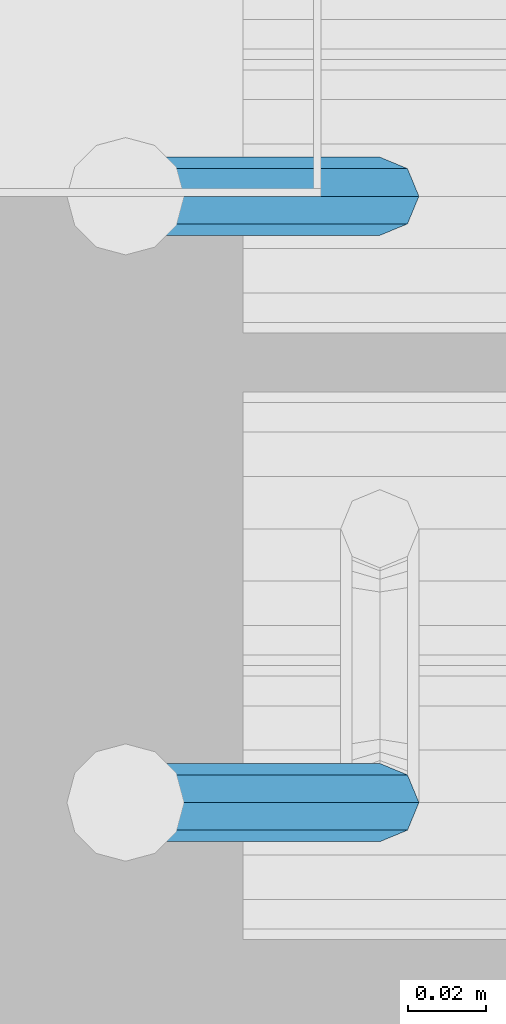
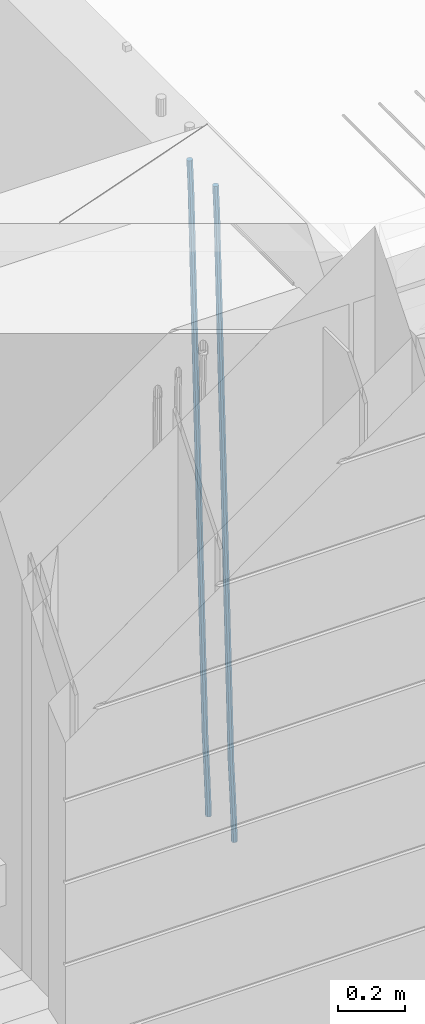
# One storey, part 99 of 350: 2 beams, 1 element without a shape of its own.
"""IFC2X3 building model written with IfcOpenShell, lengths in millimetres."""

from ifc_helpers import new_model, si_unit, frame, origin_with_axes, place, context, subcontext, project, spatial, faceted_brep, material, type_object, element, aggregate, save


model = new_model("IFC2X3")

# Units and contexts
model_context = context("Model", 3, precision=1e-05, world=origin_with_axes())
body_context = subcontext(model_context, "Body", "Model", "MODEL_VIEW")
ifc_project = project(units=[si_unit("LENGTHUNIT", "METRE", prefix="MILLI"), si_unit("AREAUNIT", "SQUARE_METRE"), si_unit("VOLUMEUNIT", "CUBIC_METRE"), si_unit("MASSUNIT", "GRAM", prefix="KILO"), si_unit("TIMEUNIT", "SECOND"), si_unit("PLANEANGLEUNIT", "RADIAN"), si_unit("SOLIDANGLEUNIT", "STERADIAN"), si_unit("THERMODYNAMICTEMPERATUREUNIT", "DEGREE_CELSIUS"), si_unit("LUMINOUSINTENSITYUNIT", "LUMEN")], contexts=[model_context])

# Site, building, storey
site_placement = place(None, origin_with_axes())
site = spatial("IfcSite", under=ifc_project, at=site_placement, CompositionType="ELEMENT")
building_placement = place(site_placement, origin_with_axes())
building = spatial("IfcBuilding", under=site, at=building_placement, CompositionType="ELEMENT")
storey_placement = place(building_placement, origin_with_axes())
storey = spatial("IfcBuildingStorey", under=building, at=storey_placement, Name="2", CompositionType="ELEMENT", Elevation=0.0)

# Assembly, beams
assembly_placement = place(storey_placement, origin_with_axes())
assembly = element("IfcElementAssembly", 1, at=assembly_placement, inside=storey, AssemblyPlace="NOTDEFINED", PredefinedType="REINFORCEMENT_UNIT")
ifc_material = material()
beam_type = type_object("IfcBeamType", Name="D20", PredefinedType="NOTDEFINED")
beam_1_placement = place(assembly_placement, frame((16725.0000022791, 8665.00000000393, 84990.0), z_axis=(-0.999642804636942, -0.000205726999925762, -0.0267249099902983), x_axis=(-0.0267249099948371, 4.30000201934385e-08, 0.999642825806181)))
beam_1 = element("IfcBeam", 2, at=beam_1_placement, type_object=beam_type, material=ifc_material, Name="JM20", ObjectType="D20", context=body_context, shape_type="Brep", body=[
    faceted_brep([(0.0, -10.0, 0.0), (-4.19531716033816e-08, -7.07106781186667, -7.07106781187031), (60.4266690400545, -7.0710677960451, -7.07106780570757), (60.4266690441291, -9.99999998418934, 6.15546014159918e-09), (0.0, 0.0, -10.0), (60.426669036824, 1.58106558956206e-08, -9.99999999384454), (4.196772351861e-08, 7.07106781186303, -7.07106781186667), (60.4266690363438, 7.07106782768096, -7.07106780570757), (0.0, 10.0, 0.0), (60.4266690388904, 10.0000000158179, 6.15182216279209e-09), (4.196772351861e-08, 7.07106781185939, 7.07106781185939), (60.4266690429649, 7.07106782768096, 7.07106781802577), (0.0, 0.0, 10.0), (60.4266690461809, 1.58179318532348e-08, 10.0000000061555), (-4.19531716033816e-08, -7.07106781187031, 7.07106781185939), (60.4266690466611, -7.07106779605238, 7.07106781802213), (61.0378400410118, -7.07106779588503, -7.07106780564936), (60.991799419251, -9.99999998403655, 6.21366780251265e-09), (61.0569027789461, 1.5985278878361e-08, -9.99999999378269), (61.0378209396877, 7.07106782784831, -7.07106780564936), (60.9917724058905, 10.0000000159635, 6.21366780251265e-09), (60.9457317841297, 7.07106782781193, 7.0710678180767), (60.9266690461809, 1.59488990902901e-08, 10.0000000062028), (60.9457508854539, -7.07106779591413, 7.0710678180767), (61.6489592143771, -7.07106614513759, -7.06310863441468), (61.5568818710308, -9.9999984576425, 0.00735959856683621), (61.6870830769039, 1.71821739058942e-06, -9.99179257185824), (61.6489210170112, 7.07106947854481, -7.06310888312146), (61.556827851804, 10.0000015422847, 0.00735924683976918), (61.4647505084577, 7.07106922979438, 7.07782747982128), (61.4266266459163, 1.36643211590126e-06, 10.0065114172685), (61.464788705809, -7.07106639389531, 7.07782772852806), (176.543135720174, -7.07075579406956, -5.56673531796696), (176.451058376813, -9.99968810657447, 1.50373291501455), (176.581259582701, 0.000312069292704109, -8.49541925541052), (176.543097522794, 7.07137982961285, -5.56673556667374), (176.451004357587, 10.00031189336, 1.50373256329476), (176.35892701424, 7.07137958085514, 8.57420079627263), (176.320803151699, 0.000311717507429421, 11.5028847337162), (176.358965211621, -7.07075604281999, 8.57420104497578), (177.098753836006, -7.07075429323595, -5.55949898843028), (176.98362511232, -9.99968666800123, 1.510669025065), (177.146421932586, 0.000313595905026887, -8.48805862247536), (177.098706077581, 7.07138133041735, -5.55949936166144), (176.983557571715, 10.0003133318824, 1.51066849724157), (176.868428848029, 7.07138095712435, 8.58083651073321), (176.820760751449, 0.000313067976094317, 11.5093961447819), (176.868476606425, -7.07075466652896, 8.58083688396073), (177.654312950661, -7.07075204110879, -5.54863964998367), (177.516135294456, -9.99968450931192, 1.52107783331303), (177.711524267797, 0.000315886711177882, -8.47701274570863), (177.654255632195, 7.07138358250813, -5.54864021007961), (177.516054233929, 10.0003154905207, 1.5210770412159), (177.377876577739, 7.0713830223176, 8.59079452451624), (177.320665260588, 0.000315094497636892, 11.5191676202448), (177.377933896176, -7.07075260129932, 8.59079508461218), (299.499456785634, -7.07025810522464, -3.16697112782276), (299.361279129444, -9.99919057342777, 3.90274635547394), (299.556668102785, 0.000809822595329024, -6.09534422354773), (299.499399467197, 7.07187751838501, -3.1669716879187), (299.361198068917, 10.0008094264049, 3.90274556338045), (299.223020412712, 7.07187695819448, 10.9724630466735), (299.165809095575, 0.000809030381788034, 13.9008361423985), (299.223077731163, -7.07025866542244, 10.9724636067695), (300.03174732349, -7.07025594743027, -3.15656661289177), (299.971788958996, -9.99918809853989, 3.91467979818117), (300.056572611924, 0.000811849109595641, -6.08557274808481), (300.031722507032, 7.07187967631762, -3.15656653768019), (299.971753863239, 10.0008119014747, 3.91467990454839), (299.91179549876, 7.07187975035777, 10.9859263156177), (299.886970210311, 0.000811953817901667, 13.9149324508144), (299.911820315203, -7.0702558733974, 10.9859262404061), (300.564137759997, -7.07025623699155, -3.15794273276697), (300.582413367199, -9.99918843065097, 3.91310145956595), (300.556570941641, 0.000811577163403854, -6.0868651410201), (300.564145451674, 7.07187938674906, -3.15794274158179), (300.582424244858, 10.0008115693345, 3.91310144710224), (300.600699852032, 7.07187937566778, 10.9841456394352), (300.608266670402, 0.000811561512819026, 13.9130680476919), (300.600692160384, -7.07025624805829, 10.98414564825), (2294.16589219622, -7.0713405251372, -8.31099358700158), (2294.1841678034, -10.0002727187966, -1.23994939466866), (2294.15832537785, -0.000272710982244462, -11.2399159952547), (2294.16589988787, 7.07079509858886, -8.31099359582004), (2294.18417868105, 9.99972728118883, -1.23994940713601), (2294.20245428824, 7.07079508752213, 5.83109478519327), (2294.2100211066, -0.00027272663282929, 8.76001719345368), (2294.20244659658, -7.07134053620393, 5.83109479401173), (2294.7782683276, -7.07134085819416, -8.31257645345977), (2294.72126025338, -10.000273010919, -1.24133766827799), (2294.84007459224, -0.000273081772320438, -11.2416781768807), (2294.87047377572, 7.07079471537872, -8.31281477453012), (2294.85165844864, 9.9997269181622, -1.24167470516841), (2294.7946503744, 7.07079476544459, 5.82956408001337), (2294.73284410976, -0.000273010977252852, 8.75866580342336), (2294.7024449263, -7.07134080815013, 5.82980240107645), (2295.39054023061, -7.0793250091956, -8.30442771922026), (2295.25826128852, -10.0072756143927, -1.23419071494573), (2295.52170777075, -0.00916171800054144, -11.2326063125765), (2295.57492774284, 7.06160849139269, -8.30343918807193), (2295.51902460904, 9.99102432676591, -1.23279272078435), (2295.38674566693, 7.06307372157607, 5.83744428349019), (2295.25557812679, -0.0070895696117077, 8.76562287684646), (2295.20235815471, -7.07785977901949, 5.83645575234186), (2317.1947101649, -7.36365585014573, -8.01423575520312), (2317.06243122277, -10.2916064553428, -0.94399875092131), (2317.32587770502, -0.293492558957951, -10.9424143485521), (2317.37909767711, 6.77727765044983, -8.01324722405116), (2317.32319454331, 9.70669348581578, -0.942600756767206), (2317.1909156012, 6.77874288063322, 6.12763624751096), (2317.05974806109, -0.291420410569117, 9.0558148408636), (2317.00652808898, -7.36219061996962, 6.12664771636264), (2317.83015404257, -7.37194216843636, -8.00577862486898), (2317.72252095213, -10.300214160583, -0.935213608652703), (2317.90419832576, -0.301033978277701, -10.9347174723516), (2317.90127966482, 6.77046829039318, -8.00629749759901), (2317.82310777172, 9.70017451494641, -0.935947405505431), (2317.71547468127, 6.77190252279979, 6.13461761071085), (2317.64143039809, -0.29900566735887, 9.06355645819713), (2317.64434905903, -7.37050793602975, 6.13513648344451), (2318.46565174212, -7.3700661537805, -7.99751648408346), (2318.38266643914, -10.2982456018653, -0.926623872735945), (2318.48256818345, -0.299336209594912, -10.9272153854981), (2318.42350634121, 6.77200652527245, -7.99954269419686), (2318.32306384158, 9.70166538090416, -0.929489366557391), (2318.2400785386, 6.77348593281204, 6.14140324480104), (2318.22316209726, -0.297244011366274, 9.07110214621207), (2318.2822239395, -7.36858674623363, 6.1434294549108), (2418.48643733139, -7.07180401323421, -6.70013846199799), (2418.4034520284, -9.99998346132634, 0.370754149349523), (2418.5033537727, -0.00107406904135132, -9.62983736341266), (2418.44429193046, 7.07026866581873, -6.70216467211139), (2418.34384943081, 9.99992752145772, 0.367888655531715), (2418.26086412782, 7.0717480733656, 7.43878126688651), (2418.24394768651, 0.00101812917273492, 10.3684801682975), (2418.30300952874, -7.07032460568735, 7.44080747699627)], [[[0, 1, 2, 3]], [[1, 4, 5, 2]], [[4, 6, 7, 5]], [[6, 8, 9, 7]], [[8, 10, 11, 9]], [[10, 12, 13, 11]], [[12, 14, 15, 13]], [[14, 0, 3, 15]], [[14, 12, 10, 8, 6, 4, 1, 0]], [[3, 2, 16, 17]], [[2, 5, 18, 16]], [[5, 7, 19, 18]], [[7, 9, 20, 19]], [[9, 11, 21, 20]], [[11, 13, 22, 21]], [[13, 15, 23, 22]], [[15, 3, 17, 23]], [[17, 16, 24, 25]], [[16, 18, 26, 24]], [[18, 19, 27, 26]], [[19, 20, 28, 27]], [[20, 21, 29, 28]], [[21, 22, 30, 29]], [[22, 23, 31, 30]], [[23, 17, 25, 31]], [[25, 24, 32, 33]], [[24, 26, 34, 32]], [[26, 27, 35, 34]], [[27, 28, 36, 35]], [[28, 29, 37, 36]], [[29, 30, 38, 37]], [[30, 31, 39, 38]], [[31, 25, 33, 39]], [[33, 32, 40, 41]], [[32, 34, 42, 40]], [[34, 35, 43, 42]], [[35, 36, 44, 43]], [[36, 37, 45, 44]], [[37, 38, 46, 45]], [[38, 39, 47, 46]], [[39, 33, 41, 47]], [[41, 40, 48, 49]], [[40, 42, 50, 48]], [[42, 43, 51, 50]], [[43, 44, 52, 51]], [[44, 45, 53, 52]], [[45, 46, 54, 53]], [[46, 47, 55, 54]], [[47, 41, 49, 55]], [[49, 48, 56, 57]], [[48, 50, 58, 56]], [[50, 51, 59, 58]], [[51, 52, 60, 59]], [[52, 53, 61, 60]], [[53, 54, 62, 61]], [[54, 55, 63, 62]], [[55, 49, 57, 63]], [[57, 56, 64, 65]], [[56, 58, 66, 64]], [[58, 59, 67, 66]], [[59, 60, 68, 67]], [[60, 61, 69, 68]], [[61, 62, 70, 69]], [[62, 63, 71, 70]], [[63, 57, 65, 71]], [[65, 64, 72, 73]], [[64, 66, 74, 72]], [[66, 67, 75, 74]], [[67, 68, 76, 75]], [[68, 69, 77, 76]], [[69, 70, 78, 77]], [[70, 71, 79, 78]], [[71, 65, 73, 79]], [[73, 72, 80, 81]], [[72, 74, 82, 80]], [[74, 75, 83, 82]], [[75, 76, 84, 83]], [[76, 77, 85, 84]], [[77, 78, 86, 85]], [[78, 79, 87, 86]], [[79, 73, 81, 87]], [[81, 80, 88, 89]], [[80, 82, 90, 88]], [[82, 83, 91, 90]], [[83, 84, 92, 91]], [[84, 85, 93, 92]], [[85, 86, 94, 93]], [[86, 87, 95, 94]], [[87, 81, 89, 95]], [[89, 88, 96, 97]], [[88, 90, 98, 96]], [[90, 91, 99, 98]], [[91, 92, 100, 99]], [[92, 93, 101, 100]], [[93, 94, 102, 101]], [[94, 95, 103, 102]], [[95, 89, 97, 103]], [[97, 96, 104, 105]], [[96, 98, 106, 104]], [[98, 99, 107, 106]], [[99, 100, 108, 107]], [[100, 101, 109, 108]], [[101, 102, 110, 109]], [[102, 103, 111, 110]], [[103, 97, 105, 111]], [[105, 104, 112, 113]], [[104, 106, 114, 112]], [[106, 107, 115, 114]], [[107, 108, 116, 115]], [[108, 109, 117, 116]], [[109, 110, 118, 117]], [[110, 111, 119, 118]], [[111, 105, 113, 119]], [[113, 112, 120, 121]], [[112, 114, 122, 120]], [[114, 115, 123, 122]], [[115, 116, 124, 123]], [[116, 117, 125, 124]], [[117, 118, 126, 125]], [[118, 119, 127, 126]], [[119, 113, 121, 127]], [[121, 120, 128, 129]], [[120, 122, 130, 128]], [[122, 123, 131, 130]], [[123, 124, 132, 131]], [[124, 125, 133, 132]], [[125, 126, 134, 133]], [[126, 127, 135, 134]], [[127, 121, 129, 135]], [[130, 131, 132, 133, 134, 135, 129, 128]]]),
])
beam_2_placement = place(assembly_placement, frame((16725.0000022791, 8820.00000000393, 84990.0), z_axis=(-0.999642804636942, -0.000205726999925762, -0.0267249099902983), x_axis=(-0.0267249099948371, 4.30000201934385e-08, 0.999642825806181)))
beam_2 = element("IfcBeam", 3, at=beam_2_placement, type_object=beam_type, material=ifc_material, Name="JM20", ObjectType="D20", context=body_context, shape_type="Brep", body=[
    faceted_brep([(0.0, -10.0, 0.0), (-4.19531716033816e-08, -7.07106781186667, -7.07106781187031), (60.4266690400545, -7.0710677960451, -7.07106780570757), (60.4266690441291, -9.99999998418934, 6.15546014159918e-09), (0.0, 0.0, -10.0), (60.426669036824, 1.58106558956206e-08, -9.99999999384454), (4.196772351861e-08, 7.07106781186303, -7.07106781186667), (60.4266690363438, 7.07106782768096, -7.07106780570757), (0.0, 10.0, 0.0), (60.4266690388904, 10.0000000158179, 6.15182216279209e-09), (4.196772351861e-08, 7.07106781185939, 7.07106781185939), (60.4266690429649, 7.07106782768096, 7.07106781802577), (0.0, 0.0, 10.0), (60.4266690461809, 1.58179318532348e-08, 10.0000000061555), (-4.19531716033816e-08, -7.07106781187031, 7.07106781185939), (60.4266690466611, -7.07106779605238, 7.07106781802213), (61.0378400410118, -7.07106779588503, -7.07106780564936), (60.991799419251, -9.99999998403655, 6.21366780251265e-09), (61.0569027789461, 1.5985278878361e-08, -9.99999999378269), (61.0378209396877, 7.07106782784831, -7.07106780564936), (60.9917724058905, 10.0000000159635, 6.21366780251265e-09), (60.9457317841297, 7.07106782781193, 7.0710678180767), (60.9266690461809, 1.59488990902901e-08, 10.0000000062028), (60.9457508854539, -7.07106779591413, 7.0710678180767), (61.6489592143771, -7.07106614513759, -7.06310863441468), (61.5568818710308, -9.9999984576425, 0.00735959856683621), (61.6870830769039, 1.71821739058942e-06, -9.99179257185824), (61.6489210170112, 7.07106947854481, -7.06310888312146), (61.556827851804, 10.0000015422847, 0.00735924683976918), (61.4647505084577, 7.07106922979438, 7.07782747982128), (61.4266266459163, 1.36643211590126e-06, 10.0065114172685), (61.464788705809, -7.07106639389531, 7.07782772852806), (176.543135720174, -7.07075579406956, -5.56673531796696), (176.451058376813, -9.99968810657447, 1.50373291501455), (176.581259582701, 0.000312069292704109, -8.49541925541052), (176.543097522794, 7.07137982961285, -5.56673556667374), (176.451004357587, 10.00031189336, 1.50373256329476), (176.35892701424, 7.07137958085514, 8.57420079627263), (176.320803151699, 0.000311717507429421, 11.5028847337162), (176.358965211621, -7.07075604281999, 8.57420104497578), (177.098753836006, -7.07075429323595, -5.55949898843028), (176.98362511232, -9.99968666800123, 1.510669025065), (177.146421932586, 0.000313595905026887, -8.48805862247536), (177.098706077581, 7.07138133041735, -5.55949936166144), (176.983557571715, 10.0003133318824, 1.51066849724157), (176.868428848029, 7.07138095712435, 8.58083651073321), (176.820760751449, 0.000313067976094317, 11.5093961447819), (176.868476606425, -7.07075466652896, 8.58083688396073), (177.654312950661, -7.07075204110879, -5.54863964998367), (177.516135294456, -9.99968450931192, 1.52107783331303), (177.711524267797, 0.000315886711177882, -8.47701274570863), (177.654255632195, 7.07138358250813, -5.54864021007961), (177.516054233929, 10.0003154905207, 1.5210770412159), (177.377876577739, 7.0713830223176, 8.59079452451624), (177.320665260588, 0.000315094497636892, 11.5191676202448), (177.377933896176, -7.07075260129932, 8.59079508461218), (299.499456785634, -7.07025810522464, -3.16697112782276), (299.361279129444, -9.99919057342777, 3.90274635547394), (299.556668102785, 0.000809822595329024, -6.09534422354773), (299.499399467197, 7.07187751838501, -3.1669716879187), (299.361198068917, 10.0008094264049, 3.90274556338045), (299.223020412712, 7.07187695819448, 10.9724630466735), (299.165809095575, 0.000809030381788034, 13.9008361423985), (299.223077731163, -7.07025866542244, 10.9724636067695), (300.03174732349, -7.07025594743027, -3.15656661289177), (299.971788958996, -9.99918809853989, 3.91467979818117), (300.056572611924, 0.000811849109595641, -6.08557274808481), (300.031722507032, 7.07187967631762, -3.15656653768019), (299.971753863239, 10.0008119014747, 3.91467990454839), (299.91179549876, 7.07187975035777, 10.9859263156177), (299.886970210311, 0.000811953817901667, 13.9149324508144), (299.911820315203, -7.0702558733974, 10.9859262404061), (300.564137759997, -7.07025623699155, -3.15794273276697), (300.582413367199, -9.99918843065097, 3.91310145956595), (300.556570941641, 0.000811577163403854, -6.0868651410201), (300.564145451674, 7.07187938674906, -3.15794274158179), (300.582424244858, 10.0008115693345, 3.91310144710224), (300.600699852032, 7.07187937566778, 10.9841456394352), (300.608266670402, 0.000811561512819026, 13.9130680476919), (300.600692160384, -7.07025624805829, 10.98414564825), (2294.16589219622, -7.0713405251372, -8.31099358700158), (2294.1841678034, -10.0002727187966, -1.23994939466866), (2294.15832537785, -0.000272710982244462, -11.2399159952547), (2294.16589988787, 7.07079509858886, -8.31099359582004), (2294.18417868105, 9.99972728118883, -1.23994940713601), (2294.20245428824, 7.07079508752213, 5.83109478519327), (2294.2100211066, -0.00027272663282929, 8.76001719345368), (2294.20244659658, -7.07134053620393, 5.83109479401173), (2294.7782683276, -7.07134085819416, -8.31257645345977), (2294.72126025338, -10.000273010919, -1.24133766827799), (2294.84007459224, -0.000273081772320438, -11.2416781768807), (2294.87047377572, 7.07079471537872, -8.31281477453012), (2294.85165844864, 9.9997269181622, -1.24167470516841), (2294.7946503744, 7.07079476544459, 5.82956408001337), (2294.73284410976, -0.000273010977252852, 8.75866580342336), (2294.7024449263, -7.07134080815013, 5.82980240107645), (2295.39054023061, -7.0793250091956, -8.30442771922026), (2295.25826128852, -10.0072756143927, -1.23419071494573), (2295.52170777075, -0.00916171800054144, -11.2326063125765), (2295.57492774284, 7.06160849139269, -8.30343918807193), (2295.51902460904, 9.99102432676591, -1.23279272078435), (2295.38674566693, 7.06307372157607, 5.83744428349019), (2295.25557812679, -0.0070895696117077, 8.76562287684646), (2295.20235815471, -7.07785977901949, 5.83645575234186), (2317.1947101649, -7.36365585014573, -8.01423575520312), (2317.06243122277, -10.2916064553428, -0.94399875092131), (2317.32587770502, -0.293492558957951, -10.9424143485521), (2317.37909767711, 6.77727765044983, -8.01324722405116), (2317.32319454331, 9.70669348581578, -0.942600756767206), (2317.1909156012, 6.77874288063322, 6.12763624751096), (2317.05974806109, -0.291420410569117, 9.0558148408636), (2317.00652808898, -7.36219061996962, 6.12664771636264), (2317.83015404257, -7.37194216843636, -8.00577862486898), (2317.72252095213, -10.300214160583, -0.935213608652703), (2317.90419832576, -0.301033978277701, -10.9347174723516), (2317.90127966482, 6.77046829039318, -8.00629749759901), (2317.82310777172, 9.70017451494641, -0.935947405505431), (2317.71547468127, 6.77190252279979, 6.13461761071085), (2317.64143039809, -0.29900566735887, 9.06355645819713), (2317.64434905903, -7.37050793602975, 6.13513648344451), (2318.46565174212, -7.3700661537805, -7.99751648408346), (2318.38266643914, -10.2982456018653, -0.926623872735945), (2318.48256818345, -0.299336209594912, -10.9272153854981), (2318.42350634121, 6.77200652527245, -7.99954269419686), (2318.32306384158, 9.70166538090416, -0.929489366557391), (2318.2400785386, 6.77348593281204, 6.14140324480104), (2318.22316209726, -0.297244011366274, 9.07110214621207), (2318.2822239395, -7.36858674623363, 6.1434294549108), (2418.48643733139, -7.07180401323421, -6.70013846199799), (2418.4034520284, -9.99998346132634, 0.370754149349523), (2418.5033537727, -0.00107406904135132, -9.62983736341266), (2418.44429193046, 7.07026866581873, -6.70216467211139), (2418.34384943081, 9.99992752145772, 0.367888655531715), (2418.26086412782, 7.0717480733656, 7.43878126688651), (2418.24394768651, 0.00101812917273492, 10.3684801682975), (2418.30300952874, -7.07032460568735, 7.44080747699627)], [[[0, 1, 2, 3]], [[1, 4, 5, 2]], [[4, 6, 7, 5]], [[6, 8, 9, 7]], [[8, 10, 11, 9]], [[10, 12, 13, 11]], [[12, 14, 15, 13]], [[14, 0, 3, 15]], [[14, 12, 10, 8, 6, 4, 1, 0]], [[3, 2, 16, 17]], [[2, 5, 18, 16]], [[5, 7, 19, 18]], [[7, 9, 20, 19]], [[9, 11, 21, 20]], [[11, 13, 22, 21]], [[13, 15, 23, 22]], [[15, 3, 17, 23]], [[17, 16, 24, 25]], [[16, 18, 26, 24]], [[18, 19, 27, 26]], [[19, 20, 28, 27]], [[20, 21, 29, 28]], [[21, 22, 30, 29]], [[22, 23, 31, 30]], [[23, 17, 25, 31]], [[25, 24, 32, 33]], [[24, 26, 34, 32]], [[26, 27, 35, 34]], [[27, 28, 36, 35]], [[28, 29, 37, 36]], [[29, 30, 38, 37]], [[30, 31, 39, 38]], [[31, 25, 33, 39]], [[33, 32, 40, 41]], [[32, 34, 42, 40]], [[34, 35, 43, 42]], [[35, 36, 44, 43]], [[36, 37, 45, 44]], [[37, 38, 46, 45]], [[38, 39, 47, 46]], [[39, 33, 41, 47]], [[41, 40, 48, 49]], [[40, 42, 50, 48]], [[42, 43, 51, 50]], [[43, 44, 52, 51]], [[44, 45, 53, 52]], [[45, 46, 54, 53]], [[46, 47, 55, 54]], [[47, 41, 49, 55]], [[49, 48, 56, 57]], [[48, 50, 58, 56]], [[50, 51, 59, 58]], [[51, 52, 60, 59]], [[52, 53, 61, 60]], [[53, 54, 62, 61]], [[54, 55, 63, 62]], [[55, 49, 57, 63]], [[57, 56, 64, 65]], [[56, 58, 66, 64]], [[58, 59, 67, 66]], [[59, 60, 68, 67]], [[60, 61, 69, 68]], [[61, 62, 70, 69]], [[62, 63, 71, 70]], [[63, 57, 65, 71]], [[65, 64, 72, 73]], [[64, 66, 74, 72]], [[66, 67, 75, 74]], [[67, 68, 76, 75]], [[68, 69, 77, 76]], [[69, 70, 78, 77]], [[70, 71, 79, 78]], [[71, 65, 73, 79]], [[73, 72, 80, 81]], [[72, 74, 82, 80]], [[74, 75, 83, 82]], [[75, 76, 84, 83]], [[76, 77, 85, 84]], [[77, 78, 86, 85]], [[78, 79, 87, 86]], [[79, 73, 81, 87]], [[81, 80, 88, 89]], [[80, 82, 90, 88]], [[82, 83, 91, 90]], [[83, 84, 92, 91]], [[84, 85, 93, 92]], [[85, 86, 94, 93]], [[86, 87, 95, 94]], [[87, 81, 89, 95]], [[89, 88, 96, 97]], [[88, 90, 98, 96]], [[90, 91, 99, 98]], [[91, 92, 100, 99]], [[92, 93, 101, 100]], [[93, 94, 102, 101]], [[94, 95, 103, 102]], [[95, 89, 97, 103]], [[97, 96, 104, 105]], [[96, 98, 106, 104]], [[98, 99, 107, 106]], [[99, 100, 108, 107]], [[100, 101, 109, 108]], [[101, 102, 110, 109]], [[102, 103, 111, 110]], [[103, 97, 105, 111]], [[105, 104, 112, 113]], [[104, 106, 114, 112]], [[106, 107, 115, 114]], [[107, 108, 116, 115]], [[108, 109, 117, 116]], [[109, 110, 118, 117]], [[110, 111, 119, 118]], [[111, 105, 113, 119]], [[113, 112, 120, 121]], [[112, 114, 122, 120]], [[114, 115, 123, 122]], [[115, 116, 124, 123]], [[116, 117, 125, 124]], [[117, 118, 126, 125]], [[118, 119, 127, 126]], [[119, 113, 121, 127]], [[121, 120, 128, 129]], [[120, 122, 130, 128]], [[122, 123, 131, 130]], [[123, 124, 132, 131]], [[124, 125, 133, 132]], [[125, 126, 134, 133]], [[126, 127, 135, 134]], [[127, 121, 129, 135]], [[130, 131, 132, 133, 134, 135, 129, 128]]]),
])
aggregate(assembly, [beam_1, beam_2])

save(model, "model.ifc")
